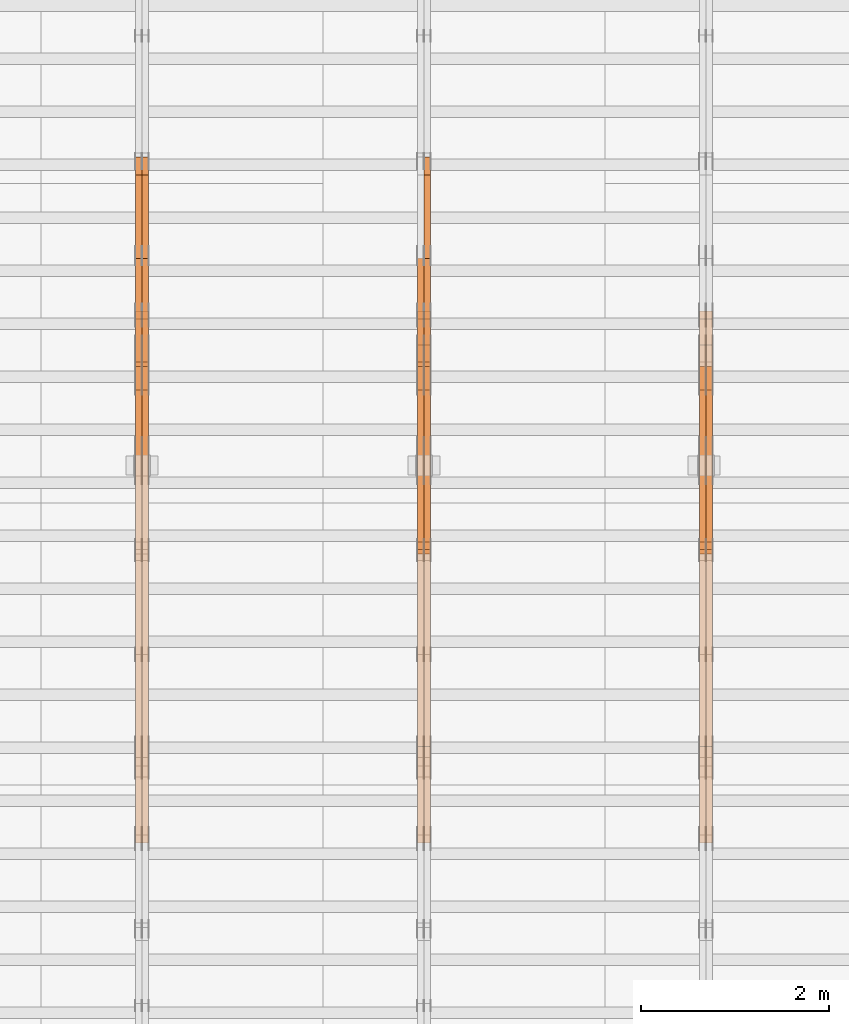
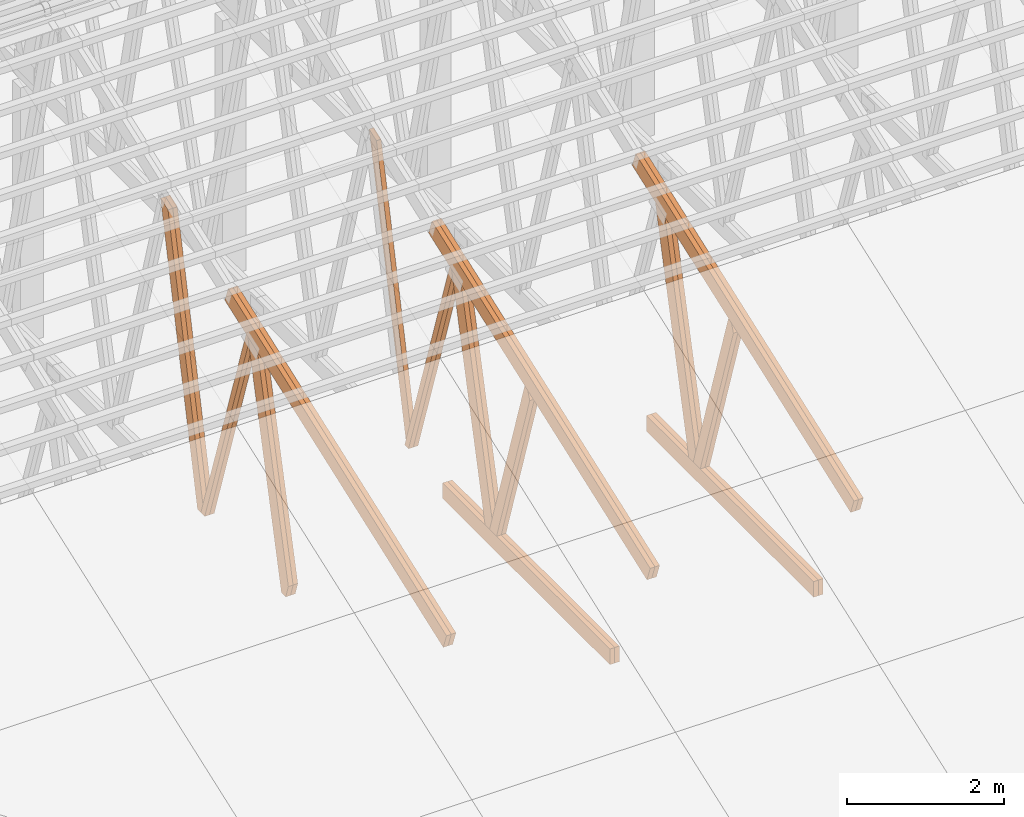
# One storey, part 28 of 189: 27 proxies.
"""IFC2X3 building model written with IfcOpenShell, lengths in millimetres."""

import ifcopenshell
import ifcopenshell.guid

model = None  # the IFC model being written
_history = None  # IfcOwnerHistory: only IFC2X3 demands one
_inside = {}  # id of a spatial element -> (the spatial element, [elements in it])
_under = {}  # id of a project, library or spatial element -> (it, [spatial elements below it])
_declared = {}  # id of a project -> (the project, [libraries it declares])
_typed = {}  # id of a type object -> (the type object, [elements of that type])
_made_of = {}  # id of a material, layer set ... -> (it, [elements and type objects made of it])


def new_model(schema):
    """Start an empty IFC model of exactly this schema.

    Asked for "IFC4X3", IfcOpenShell would pick the latest addendum, in which some entities
    have other attributes; the version numbers below select the first issue.
    IFC2X3 requires an IfcOwnerHistory on every rooted entity: one is made here for all.
    """
    global model, _history
    if schema == "IFC4X3":
        model = ifcopenshell.file(schema_version=(4, 3, 0, 0))
    else:
        model = ifcopenshell.file(schema=schema)
    _inside.clear()
    _under.clear()
    _declared.clear()
    _typed.clear()
    _made_of.clear()
    _history = None
    if model.schema == "IFC2X3":
        org = make("IfcOrganization", Name="unknown")
        user = make(
            "IfcPersonAndOrganization",
            ThePerson=make("IfcPerson", FamilyName="unknown"),
            TheOrganization=org,
        )
        app = make(
            "IfcApplication",
            ApplicationDeveloper=org,
            Version="unknown",
            ApplicationFullName="unknown",
            ApplicationIdentifier="unknown",
        )
        _history = make(
            "IfcOwnerHistory",
            OwningUser=user,
            OwningApplication=app,
            ChangeAction="ADDED",
            CreationDate=0,
        )
    return model


def make(cls, **values):
    """One entity of the class cls with the attributes given. An attribute that is None is left unset."""
    return model.create_entity(
        cls, **{name: value for name, value in values.items() if value is not None}
    )


def entity(cls, *values):
    """Any entity or typed value of the class cls, its attributes in the order of the schema. None: left unset."""
    e = model.create_entity(cls)
    for i, value in enumerate(values):
        if value is not None:
            e[i] = value
    return e


def rooted(cls, **values):
    """An entity with a GlobalId (a new one), such as an element, a storey or a relation."""
    return make(cls, GlobalId=ifcopenshell.guid.new(), OwnerHistory=_history, **values)


def si_unit(unit_type, name, prefix=None):
    """IfcSIUnit, for example si_unit("LENGTHUNIT", "METRE", prefix="MILLI")."""
    return make("IfcSIUnit", UnitType=unit_type, Prefix=prefix, Name=name)


def converted_unit(unit_type, name, factor, base, dimensions=None, offset=None):
    """IfcConversionBasedUnit, such as the inch: factor (a typed value) times the base unit."""
    return make(
        "IfcConversionBasedUnit"
        if offset is None
        else "IfcConversionBasedUnitWithOffset",
        ConversionOffset=offset,
        Dimensions=None
        if dimensions is None
        else entity("IfcDimensionalExponents", *dimensions),
        UnitType=unit_type,
        Name=name,
        ConversionFactor=make(
            "IfcMeasureWithUnit", ValueComponent=factor, UnitComponent=base
        ),
    )


def derived_unit(unit_type, elements):
    """IfcDerivedUnit: a product of units, each with its exponent."""
    return make(
        "IfcDerivedUnit",
        Elements=[
            make("IfcDerivedUnitElement", Unit=unit, Exponent=power)
            for unit, power in elements
        ],
        UnitType=unit_type,
    )


def assignment(units):
    """IfcUnitAssignment: the units of a project."""
    return None if units is None else make("IfcUnitAssignment", Units=units)


def point(xyz):
    """IfcCartesianPoint."""
    return None if xyz is None else make("IfcCartesianPoint", Coordinates=xyz)


def direction(xyz):
    """IfcDirection."""
    return None if xyz is None else make("IfcDirection", DirectionRatios=xyz)


def frame(location, z_axis=None, x_axis=None):
    """IfcAxis2Placement3D, a coordinate frame: its origin and axes. An axis left out is left unset."""
    return make(
        "IfcAxis2Placement3D",
        Location=point(location),
        Axis=direction(z_axis),
        RefDirection=direction(x_axis),
    )


def frame_2d(location, x_axis=None):
    """IfcAxis2Placement2D, a coordinate frame in the plane: its origin and x axis."""
    return make(
        "IfcAxis2Placement2D", Location=point(location), RefDirection=direction(x_axis)
    )


def origin():
    """The frame at (0, 0, 0) with its axes left unset."""
    return frame((0.0, 0.0, 0.0))


def origin_2d_with_axis():
    """The frame at (0, 0) in the plane with the x axis (1, 0) written out."""
    return frame_2d((0.0, 0.0), x_axis=(1.0, 0.0))


def place(relative_to, where):
    """IfcLocalPlacement: puts the frame where relative to a parent placement (None: the world)."""
    return make(
        "IfcLocalPlacement", PlacementRelTo=relative_to, RelativePlacement=where
    )


def context(
    kind, dimensions, precision=None, world=None, true_north=None, identifier=None
):
    """IfcGeometricRepresentationContext, for example the 3D "Model" context."""
    return make(
        "IfcGeometricRepresentationContext",
        ContextIdentifier=identifier,
        ContextType=kind,
        CoordinateSpaceDimension=dimensions,
        Precision=precision,
        WorldCoordinateSystem=world,
        TrueNorth=true_north,
    )


def subcontext(parent, identifier, kind, view, scale=None):
    """IfcGeometricRepresentationSubContext, for example "Body" below "Model"."""
    return make(
        "IfcGeometricRepresentationSubContext",
        ContextIdentifier=identifier,
        ContextType=kind,
        ParentContext=parent,
        TargetScale=scale,
        TargetView=view,
    )


def project(units=None, contexts=None):
    """IfcProject with its units and contexts."""
    return rooted(
        "IfcProject",
        Name="project",
        RepresentationContexts=contexts,
        UnitsInContext=assignment(units),
    )


def spatial(cls, under=None, at=None, **own):
    """A site, building, storey or space (cls), placed at a placement, below another one or the project."""
    s = rooted(cls, ObjectPlacement=at, **own)
    if under is not None:
        _under.setdefault(under.id(), (under, []))[1].append(s)
    return s


def polyline(points):
    """IfcPolyline through the points."""
    return make("IfcPolyline", Points=[point(p) for p in points])


def profile(cls, at=None, kind="AREA", **sizes):
    """A parametric profile (cls). Its sizes go by their IFC names, for example OverallWidth=200.0."""
    return make(cls, ProfileType=kind, Position=at, **sizes)


def rectangle(**sizes):
    """IfcRectangleProfileDef."""
    return profile("IfcRectangleProfileDef", **sizes)


def outline(outer, holes=None, kind="AREA"):
    """IfcArbitraryClosedProfileDef: a profile drawn as a closed curve; with holes, ...WithVoids."""
    if holes is None:
        return make("IfcArbitraryClosedProfileDef", ProfileType=kind, OuterCurve=outer)
    return make(
        "IfcArbitraryProfileDefWithVoids",
        ProfileType=kind,
        OuterCurve=outer,
        InnerCurves=holes,
    )


def extrude(swept, where, along, depth):
    """IfcExtrudedAreaSolid: the profile swept, set in the frame where, extruded along a direction by depth."""
    return make(
        "IfcExtrudedAreaSolid",
        SweptArea=swept,
        Position=where,
        ExtrudedDirection=direction(along),
        Depth=depth,
    )


def shape(context_of_items, identifier, shape_type, items):
    """IfcShapeRepresentation: the items that make up one representation, for example the "Body"."""
    return make(
        "IfcShapeRepresentation",
        ContextOfItems=context_of_items,
        RepresentationIdentifier=identifier,
        RepresentationType=shape_type,
        Items=items,
    )


def source(mapping_origin, context_of_items, identifier, shape_type, items):
    """IfcRepresentationMap: a shape defined once, which mapped items show again and again."""
    return make(
        "IfcRepresentationMap",
        MappingOrigin=mapping_origin,
        MappedRepresentation=shape(context_of_items, identifier, shape_type, items),
    )


def transform(
    local_origin,
    x_axis=None,
    y_axis=None,
    z_axis=None,
    scale=None,
    scale2=None,
    scale3=None,
    uniform=True,
):
    """IfcCartesianTransformationOperator3D, or its non-uniform kind. x_axis, y_axis, z_axis: its Axis1, 2, 3."""
    if uniform:
        return make(
            "IfcCartesianTransformationOperator3D",
            Axis1=direction(x_axis),
            Axis2=direction(y_axis),
            LocalOrigin=point(local_origin),
            Scale=scale,
            Axis3=direction(z_axis),
        )
    return make(
        "IfcCartesianTransformationOperator3DnonUniform",
        Axis1=direction(x_axis),
        Axis2=direction(y_axis),
        LocalOrigin=point(local_origin),
        Scale=scale,
        Axis3=direction(z_axis),
        Scale2=scale2,
        Scale3=scale3,
    )


def mapped(mapping_source, mapping_target):
    """IfcMappedItem: shows the shape of a source again, moved by a transform."""
    return make(
        "IfcMappedItem", MappingSource=mapping_source, MappingTarget=mapping_target
    )


def material(Name=None, Category=None):
    """IfcMaterial."""
    return make("IfcMaterial", Name=Name, Category=Category)


def made_of(thing, what):
    """Note that an element or type object is made of a material, layer set ...; save() writes the relation."""
    if what is not None:
        _made_of.setdefault(what.id(), (what, []))[1].append(thing)
    return thing


def type_object(cls, material=None, **own):
    """A type object (cls), such as IfcWallType, which elements share."""
    return made_of(rooted(cls, **own), material)


def type_shapes(of_type, sources):
    """Give a type object the sources (RepresentationMaps) that its elements show as mapped items."""
    of_type.RepresentationMaps = sources


def element(
    cls,
    number,
    at=None,
    inside=None,
    cuts=None,
    type_object=None,
    material=None,
    context=None,
    identifier="Body",
    shape_type=None,
    held_by="IfcProductDefinitionShape",
    body=None,
    shapes=None,
    **own,
):
    """One element of the class cls, such as IfcWall. Its Tag is "e" and its number.

    at: its placement. inside: the storey or other place that contains it. cuts: it is an
    opening in that element (IfcRelVoidsElement). A single representation is given by context,
    identifier, shape_type and body (its items); several are given by shapes. held_by: the class
    of the entity that holds the representations. save() writes the other relations.
    """
    e = rooted(cls, Tag="e%d" % number, ObjectPlacement=at, **own)
    if body is not None:
        shapes = [shape(context, identifier, shape_type, body)]
    if shapes is not None:
        e.Representation = make(held_by, Representations=shapes)
    if inside is not None:
        _inside.setdefault(inside.id(), (inside, []))[1].append(e)
    if cuts is not None:
        rooted(
            "IfcRelVoidsElement", RelatingBuildingElement=cuts, RelatedOpeningElement=e
        )
    if type_object is not None:
        _typed.setdefault(type_object.id(), (type_object, []))[1].append(e)
    return made_of(e, material)


def aggregate(whole, parts):
    """IfcRelAggregates: a whole, such as a stair, and the parts it consists of."""
    return rooted("IfcRelAggregates", RelatingObject=whole, RelatedObjects=parts)


def save(model, path):
    """Write the relations noted so far, then the file.

    IfcRelAggregates (storeys below a building ...), IfcRelContainedInSpatialStructure (elements
    in a storey), IfcRelDefinesByType, IfcRelAssociatesMaterial and IfcRelDeclares: one each for
    every whole, place, type object, material and project.
    """
    for whole, parts in _under.values():
        aggregate(whole, parts)
    for where, things in _inside.values():
        rooted(
            "IfcRelContainedInSpatialStructure",
            RelatedElements=things,
            RelatingStructure=where,
        )
    for kind, things in _typed.values():
        rooted("IfcRelDefinesByType", RelatedObjects=things, RelatingType=kind)
    for what, things in _made_of.values():
        rooted("IfcRelAssociatesMaterial", RelatedObjects=things, RelatingMaterial=what)
    for by, libraries in _declared.values():
        rooted("IfcRelDeclares", RelatingContext=by, RelatedDefinitions=libraries)
    model.write(path)


model = new_model("IFC2X3")

# Units and contexts
model_context = context("Model", 3, precision=0.01, world=origin(), true_north=direction((6.12303176911189e-17, 1.0)))
body_context = subcontext(model_context, "Body", "Model", "MODEL_VIEW")
ifc_project = project(units=[si_unit("LENGTHUNIT", "METRE", prefix="MILLI"), si_unit("AREAUNIT", "SQUARE_METRE"), si_unit("VOLUMEUNIT", "CUBIC_METRE"), converted_unit("PLANEANGLEUNIT", "DEGREE", entity("IfcRatioMeasure", 0.0174532925199433), si_unit("PLANEANGLEUNIT", "RADIAN"), dimensions=[0, 0, 0, 0, 0, 0, 0]), si_unit("MASSUNIT", "GRAM", prefix="KILO"), derived_unit("MASSDENSITYUNIT", [(si_unit("MASSUNIT", "GRAM", prefix="KILO"), 1), (si_unit("LENGTHUNIT", "METRE"), -3)]), si_unit("TIMEUNIT", "SECOND"), si_unit("FREQUENCYUNIT", "HERTZ"), si_unit("THERMODYNAMICTEMPERATUREUNIT", "DEGREE_CELSIUS"), derived_unit("THERMALTRANSMITTANCEUNIT", [(si_unit("MASSUNIT", "GRAM", prefix="KILO"), 1), (si_unit("THERMODYNAMICTEMPERATUREUNIT", "KELVIN"), -1), (si_unit("TIMEUNIT", "SECOND"), -3)]), derived_unit("VOLUMETRICFLOWRATEUNIT", [(si_unit("LENGTHUNIT", "METRE"), 3), (si_unit("TIMEUNIT", "SECOND"), -1)]), si_unit("ELECTRICCURRENTUNIT", "AMPERE"), si_unit("ELECTRICVOLTAGEUNIT", "VOLT"), si_unit("POWERUNIT", "WATT"), si_unit("FORCEUNIT", "NEWTON"), si_unit("ILLUMINANCEUNIT", "LUX"), si_unit("LUMINOUSFLUXUNIT", "LUMEN"), si_unit("LUMINOUSINTENSITYUNIT", "CANDELA"), derived_unit("USERDEFINED", [(si_unit("MASSUNIT", "GRAM", prefix="KILO"), -1), (si_unit("LENGTHUNIT", "METRE"), -2), (si_unit("TIMEUNIT", "SECOND"), 3), (si_unit("LUMINOUSFLUXUNIT", "LUMEN"), 1)]), derived_unit("LINEARVELOCITYUNIT", [(si_unit("LENGTHUNIT", "METRE"), 1), (si_unit("TIMEUNIT", "SECOND"), -1)]), si_unit("PRESSUREUNIT", "PASCAL"), derived_unit("USERDEFINED", [(si_unit("LENGTHUNIT", "METRE"), -2), (si_unit("MASSUNIT", "GRAM", prefix="KILO"), 1), (si_unit("TIMEUNIT", "SECOND"), -2)])], contexts=[model_context])

# Site, building, storey
site_placement = place(None, origin())
site = spatial("IfcSite", under=ifc_project, at=site_placement, CompositionType="ELEMENT")
building_placement = place(site_placement, origin())
building = spatial("IfcBuilding", under=site, at=building_placement, CompositionType="ELEMENT")
storey_placement = place(building_placement, origin())
storey = spatial("IfcBuildingStorey", under=building, at=storey_placement, Name="Default", CompositionType="ELEMENT", Elevation=0.0)

# Proxies
ifc_material_1 = material(Name="IfcSurfaceStyle #162318")
building_element_proxy_type_1 = type_object("IfcBuildingElementProxyType", Name="T1-W1 162316", PredefinedType="NOTDEFINED", material=ifc_material_1)
shared_shape_1 = source(origin(), body_context, "Body", "SweptSolid", [
    extrude(outline(polyline([(-2144.69382208629, -109.99948311278), (1421.70798092021, -109.99948311278), (1448.88116133745, -0.000392715405943322), (1271.09900468242, 109.999679470483), (-1996.99432485378, 109.999679470483), (-2144.69382208629, -109.99948311278)])), frame((1448.88130194731, 110.000176487146, 0.0), z_axis=(0.0, 0.0, 1.0), x_axis=(-1.0, 0.0, 0.0)), (0.0, 0.0, 1.0), 69.9999999999998),
])
type_shapes(building_element_proxy_type_1, [shared_shape_1])
proxy_1_placement = place(building_placement, frame((30300.0, 8727.74270166583, 271.380182391418), z_axis=(-1.0, 0.0, 0.0), x_axis=(0.0, 0.239819839925978, 0.970817410421691)))
element("IfcBuildingElementProxy", 1, at=proxy_1_placement, inside=storey, type_object=building_element_proxy_type_1, material=ifc_material_1, Name="T1-W1", context=body_context, shape_type="MappedRepresentation", body=[
    mapped(shared_shape_1, transform((0.0, 0.0, 0.0), scale=1.0)),
])
ifc_material_2 = material(Name="IfcSurfaceStyle #162252")
building_element_proxy_type_2 = type_object("IfcBuildingElementProxyType", Name="T1-W1 162250", PredefinedType="NOTDEFINED", material=ifc_material_2)
shared_shape_2 = source(origin(), body_context, "Body", "SweptSolid", [
    extrude(outline(polyline([(-2144.69382208629, -109.99948311278), (1421.70798092021, -109.99948311278), (1448.88116133745, -0.000392715405943322), (1271.09900468242, 109.999679470483), (-1996.99432485378, 109.999679470483), (-2144.69382208629, -109.99948311278)])), frame((1448.88130194731, 110.000176487146, 0.0), z_axis=(0.0, 0.0, 1.0), x_axis=(-1.0, 0.0, 0.0)), (0.0, 0.0, 1.0), 69.9999999999998),
])
type_shapes(building_element_proxy_type_2, [shared_shape_2])
proxy_2_placement = place(building_placement, frame((30230.0, 8727.74270166583, 271.380182391418), z_axis=(-1.0, 0.0, 0.0), x_axis=(0.0, 0.239819839925978, 0.970817410421691)))
element("IfcBuildingElementProxy", 2, at=proxy_2_placement, inside=storey, type_object=building_element_proxy_type_2, material=ifc_material_2, Name="T1-W1", context=body_context, shape_type="MappedRepresentation", body=[
    mapped(shared_shape_2, transform((0.0, 0.0, 0.0), scale=1.0)),
])
ifc_material_3 = material(Name="IfcSurfaceStyle #162054")
building_element_proxy_type_3 = type_object("IfcBuildingElementProxyType", Name="T1-W4 162052", PredefinedType="NOTDEFINED", material=ifc_material_3)
shared_shape_3 = source(origin(), body_context, "Body", "SweptSolid", [
    extrude(outline(polyline([(-1688.09292256655, -85.0003489723785), (1071.44998120742, -85.0003489723785), (1178.19407811536, -0.00016040063201781), (1181.35435681367, 85.0004291726946), (-1742.9054935699, 85.0004291726946), (-1688.09292256655, -85.0003489723785)])), frame((1181.35446122976, 85.0007670757732, 0.0), z_axis=(0.0, 0.0, 1.0), x_axis=(-1.0, 0.0, 0.0)), (0.0, 0.0, 1.0), 69.9999999999998),
])
type_shapes(building_element_proxy_type_3, [shared_shape_3])
proxy_3_placement = place(building_placement, frame((30300.0, 7937.17021143291, 3028.170124945), z_axis=(-1.0, 0.0, 0.0), x_axis=(0.0, 0.306868406216492, -0.951751953644514)))
element("IfcBuildingElementProxy", 3, at=proxy_3_placement, inside=storey, type_object=building_element_proxy_type_3, material=ifc_material_3, Name="T1-W4", context=body_context, shape_type="MappedRepresentation", body=[
    mapped(shared_shape_3, transform((0.0, 0.0, 0.0), scale=1.0)),
])
ifc_material_4 = material(Name="IfcSurfaceStyle #161988")
building_element_proxy_type_4 = type_object("IfcBuildingElementProxyType", Name="T1-W4 161986", PredefinedType="NOTDEFINED", material=ifc_material_4)
shared_shape_4 = source(origin(), body_context, "Body", "SweptSolid", [
    extrude(outline(polyline([(-1688.09292256655, -85.0003489723785), (1071.44998120742, -85.0003489723785), (1178.19407811536, -0.00016040063201781), (1181.35435681367, 85.0004291726946), (-1742.9054935699, 85.0004291726946), (-1688.09292256655, -85.0003489723785)])), frame((1181.35446122976, 85.0007670757732, 0.0), z_axis=(0.0, 0.0, 1.0), x_axis=(-1.0, 0.0, 0.0)), (0.0, 0.0, 1.0), 69.9999999999998),
])
type_shapes(building_element_proxy_type_4, [shared_shape_4])
proxy_4_placement = place(building_placement, frame((30230.0, 7937.17021143291, 3028.170124945), z_axis=(-1.0, 0.0, 0.0), x_axis=(0.0, 0.306868406216492, -0.951751953644514)))
element("IfcBuildingElementProxy", 4, at=proxy_4_placement, inside=storey, type_object=building_element_proxy_type_4, material=ifc_material_4, Name="T1-W4", context=body_context, shape_type="MappedRepresentation", body=[
    mapped(shared_shape_4, transform((0.0, 0.0, 0.0), scale=1.0)),
])
ifc_material_5 = material(Name="IfcSurfaceStyle #158976")
building_element_proxy_type_5 = type_object("IfcBuildingElementProxyType", Name="T1-B6 158974", PredefinedType="NOTDEFINED", material=ifc_material_5)
shared_shape_5 = source(origin(), body_context, "Body", "SweptSolid", [
    extrude(rectangle(XDim=4266.763671875, YDim=245.000000000001, at=origin_2d_with_axis()), frame((2133.3818359375, 122.500000000001, 0.0), z_axis=(0.0, 0.0, 1.0), x_axis=(-1.0, 0.0, 0.0)), (0.0, 0.0, 1.0), 69.9999999999997),
])
type_shapes(building_element_proxy_type_5, [shared_shape_5])
proxy_5_placement = place(building_placement, frame((30300.0, 5762.466796875, 245.0), z_axis=(-1.0, 0.0, 0.0), x_axis=(0.0, 1.0, 0.0)))
element("IfcBuildingElementProxy", 5, at=proxy_5_placement, inside=storey, type_object=building_element_proxy_type_5, material=ifc_material_5, Name="T1-B6", context=body_context, shape_type="MappedRepresentation", body=[
    mapped(shared_shape_5, transform((0.0, 0.0, 0.0), scale=1.0)),
])
ifc_material_6 = material(Name="IfcSurfaceStyle #158919")
building_element_proxy_type_6 = type_object("IfcBuildingElementProxyType", Name="T1-B6 158917", PredefinedType="NOTDEFINED", material=ifc_material_6)
shared_shape_6 = source(origin(), body_context, "Body", "SweptSolid", [
    extrude(rectangle(XDim=4266.763671875, YDim=245.000000000001, at=origin_2d_with_axis()), frame((2133.3818359375, 122.500000000001, 0.0), z_axis=(0.0, 0.0, 1.0), x_axis=(-1.0, 0.0, 0.0)), (0.0, 0.0, 1.0), 69.9999999999997),
])
type_shapes(building_element_proxy_type_6, [shared_shape_6])
proxy_6_placement = place(building_placement, frame((30230.0, 5762.466796875, 245.0), z_axis=(-1.0, 0.0, 0.0), x_axis=(0.0, 1.0, 0.0)))
element("IfcBuildingElementProxy", 6, at=proxy_6_placement, inside=storey, type_object=building_element_proxy_type_6, material=ifc_material_6, Name="T1-B6", context=body_context, shape_type="MappedRepresentation", body=[
    mapped(shared_shape_6, transform((0.0, 0.0, 0.0), scale=1.0)),
])
ifc_material_7 = material(Name="IfcSurfaceStyle #158616")
building_element_proxy_type_7 = type_object("IfcBuildingElementProxyType", Name="T1-T1 158614", PredefinedType="NOTDEFINED", material=ifc_material_7)
shared_shape_7 = source(origin(), body_context, "Body", "SweptSolid", [
    extrude(outline(polyline([(-2964.99981923522, -122.500027388895), (2964.99982426074, -122.500027388895), (2964.99984011048, 122.500027388895), (-2964.99984513599, 122.500027388895), (-2964.99981923522, -122.500027388895)])), frame((2965.00021857317, 122.500056320695, 0.0), z_axis=(0.0, 0.0, 1.0), x_axis=(-1.0, 0.0, 0.0)), (0.0, 0.0, 1.0), 69.9999999999996),
])
type_shapes(building_element_proxy_type_7, [shared_shape_7])
proxy_7_placement = place(building_placement, frame((30300.0, 10391.0374749089, 3921.30478975487), z_axis=(-1.0, 0.0, 0.0), x_axis=(0.0, -0.939692620785908, -0.342020143325669)))
element("IfcBuildingElementProxy", 7, at=proxy_7_placement, inside=storey, type_object=building_element_proxy_type_7, material=ifc_material_7, Name="T1-T1", context=body_context, shape_type="MappedRepresentation", body=[
    mapped(shared_shape_7, transform((0.0, 0.0, 0.0), scale=1.0)),
])
ifc_material_8 = material(Name="IfcSurfaceStyle #158559")
building_element_proxy_type_8 = type_object("IfcBuildingElementProxyType", Name="T1-T1 158557", PredefinedType="NOTDEFINED", material=ifc_material_8)
shared_shape_8 = source(origin(), body_context, "Body", "SweptSolid", [
    extrude(outline(polyline([(-2964.99981923522, -122.500027388895), (2964.99982426074, -122.500027388895), (2964.99984011048, 122.500027388895), (-2964.99984513599, 122.500027388895), (-2964.99981923522, -122.500027388895)])), frame((2965.00021857317, 122.500056320695, 0.0), z_axis=(0.0, 0.0, 1.0), x_axis=(-1.0, 0.0, 0.0)), (0.0, 0.0, 1.0), 69.9999999999996),
])
type_shapes(building_element_proxy_type_8, [shared_shape_8])
proxy_8_placement = place(building_placement, frame((30230.0, 10391.0374749089, 3921.30478975487), z_axis=(-1.0, 0.0, 0.0), x_axis=(0.0, -0.939692620785908, -0.342020143325669)))
element("IfcBuildingElementProxy", 8, at=proxy_8_placement, inside=storey, type_object=building_element_proxy_type_8, material=ifc_material_8, Name="T1-T1", context=body_context, shape_type="MappedRepresentation", body=[
    mapped(shared_shape_8, transform((0.0, 0.0, 0.0), scale=1.0)),
])
ifc_material_9 = material(Name="IfcSurfaceStyle #147056")
building_element_proxy_type_9 = type_object("IfcBuildingElementProxyType", Name="T1-W3 147054", PredefinedType="NOTDEFINED", material=ifc_material_9)
shared_shape_9 = source(origin(), body_context, "Body", "SweptSolid", [
    extrude(outline(polyline([(-2625.55080717397, -84.9998286237256), (1749.48871563991, -84.9998286237256), (1768.20584427244, 0.000602085469291858), (1625.445846867, 85.0000405971208), (-2517.58959960538, 84.9990145648612), (-2625.55080717397, -84.9998286237256)])), frame((1768.20584427244, 85.0000405971208, 0.0), z_axis=(0.0, 0.0, 1.0), x_axis=(-1.0, 0.0, 0.0)), (0.0, 0.0, 1.0), 69.9999999999997),
])
type_shapes(building_element_proxy_type_9, [shared_shape_9])
proxy_9_placement = place(building_placement, frame((27300.0, 10918.6728403286, 263.278932236374), z_axis=(-1.0, 0.0, 0.0), x_axis=(0.0, 0.215047682154604, 0.976603550269982)))
element("IfcBuildingElementProxy", 9, at=proxy_9_placement, inside=storey, type_object=building_element_proxy_type_9, material=ifc_material_9, Name="T1-W3", context=body_context, shape_type="MappedRepresentation", body=[
    mapped(shared_shape_9, transform((0.0, 0.0, 0.0), scale=1.0)),
])
ifc_material_10 = material(Name="IfcSurfaceStyle #146792")
building_element_proxy_type_10 = type_object("IfcBuildingElementProxyType", Name="T1-W7 146790", PredefinedType="NOTDEFINED", material=ifc_material_10)
shared_shape_10 = source(origin(), body_context, "Body", "SweptSolid", [
    extrude(outline(polyline([(-2158.15323194511, -47.5001976605119), (1398.58481981178, -47.5001976605119), (1473.93376219819, -0.000131511554346808), (1475.30069254941, 47.5002634162891), (-2189.66604261427, 47.5002634162891), (-2158.15323194511, -47.5001976605119)])), frame((1475.30069254941, 47.5002634162891, 0.0), z_axis=(0.0, 0.0, 1.0), x_axis=(-1.0, 0.0, 0.0)), (0.0, 0.0, 1.0), 69.9999999999998),
])
type_shapes(building_element_proxy_type_10, [shared_shape_10])
proxy_10_placement = place(building_placement, frame((27300.0, 9847.787109375, 3723.57788085937), z_axis=(-1.0, 0.0, 0.0), x_axis=(0.0, 0.314845237923105, -0.949143021971475)))
element("IfcBuildingElementProxy", 10, at=proxy_10_placement, inside=storey, type_object=building_element_proxy_type_10, material=ifc_material_10, Name="T1-W7", context=body_context, shape_type="MappedRepresentation", body=[
    mapped(shared_shape_10, transform((0.0, 0.0, 0.0), scale=1.0)),
])
ifc_material_11 = material(Name="IfcSurfaceStyle #146726")
building_element_proxy_type_11 = type_object("IfcBuildingElementProxyType", Name="T1-W7 146724", PredefinedType="NOTDEFINED", material=ifc_material_11)
shared_shape_11 = source(origin(), body_context, "Body", "SweptSolid", [
    extrude(outline(polyline([(-2158.15323194511, -47.5001976605119), (1398.58481981178, -47.5001976605119), (1473.93376219819, -0.000131511554346808), (1475.30069254941, 47.5002634162891), (-2189.66604261427, 47.5002634162891), (-2158.15323194511, -47.5001976605119)])), frame((1475.30069254941, 47.5002634162891, 0.0), z_axis=(0.0, 0.0, 1.0), x_axis=(-1.0, 0.0, 0.0)), (0.0, 0.0, 1.0), 69.9999999999998),
])
type_shapes(building_element_proxy_type_11, [shared_shape_11])
proxy_11_placement = place(building_placement, frame((27230.0, 9847.787109375, 3723.57788085937), z_axis=(-1.0, 0.0, 0.0), x_axis=(0.0, 0.314845237923105, -0.949143021971475)))
element("IfcBuildingElementProxy", 11, at=proxy_11_placement, inside=storey, type_object=building_element_proxy_type_11, material=ifc_material_11, Name="T1-W7", context=body_context, shape_type="MappedRepresentation", body=[
    mapped(shared_shape_11, transform((0.0, 0.0, 0.0), scale=1.0)),
])
ifc_material_12 = material(Name="IfcSurfaceStyle #146528")
building_element_proxy_type_12 = type_object("IfcBuildingElementProxyType", Name="T1-W1 146526", PredefinedType="NOTDEFINED", material=ifc_material_12)
shared_shape_12 = source(origin(), body_context, "Body", "SweptSolid", [
    extrude(outline(polyline([(-2144.69382208629, -109.99948311278), (1421.70798092021, -109.99948311278), (1448.88116133745, -0.000392715405943322), (1271.09900468242, 109.999679470483), (-1996.99432485378, 109.999679470483), (-2144.69382208629, -109.99948311278)])), frame((1448.88130194731, 110.000176487146, 0.0), z_axis=(0.0, 0.0, 1.0), x_axis=(-1.0, 0.0, 0.0)), (0.0, 0.0, 1.0), 69.9999999999998),
])
type_shapes(building_element_proxy_type_12, [shared_shape_12])
proxy_12_placement = place(building_placement, frame((27300.0, 8727.74270166583, 271.380182391418), z_axis=(-1.0, 0.0, 0.0), x_axis=(0.0, 0.239819839925978, 0.970817410421691)))
element("IfcBuildingElementProxy", 12, at=proxy_12_placement, inside=storey, type_object=building_element_proxy_type_12, material=ifc_material_12, Name="T1-W1", context=body_context, shape_type="MappedRepresentation", body=[
    mapped(shared_shape_12, transform((0.0, 0.0, 0.0), scale=1.0)),
])
ifc_material_13 = material(Name="IfcSurfaceStyle #146462")
building_element_proxy_type_13 = type_object("IfcBuildingElementProxyType", Name="T1-W1 146460", PredefinedType="NOTDEFINED", material=ifc_material_13)
shared_shape_13 = source(origin(), body_context, "Body", "SweptSolid", [
    extrude(outline(polyline([(-2144.69382208629, -109.99948311278), (1421.70798092021, -109.99948311278), (1448.88116133745, -0.000392715405943322), (1271.09900468242, 109.999679470483), (-1996.99432485378, 109.999679470483), (-2144.69382208629, -109.99948311278)])), frame((1448.88130194731, 110.000176487146, 0.0), z_axis=(0.0, 0.0, 1.0), x_axis=(-1.0, 0.0, 0.0)), (0.0, 0.0, 1.0), 69.9999999999998),
])
type_shapes(building_element_proxy_type_13, [shared_shape_13])
proxy_13_placement = place(building_placement, frame((27230.0, 8727.74270166583, 271.380182391418), z_axis=(-1.0, 0.0, 0.0), x_axis=(0.0, 0.239819839925978, 0.970817410421691)))
element("IfcBuildingElementProxy", 13, at=proxy_13_placement, inside=storey, type_object=building_element_proxy_type_13, material=ifc_material_13, Name="T1-W1", context=body_context, shape_type="MappedRepresentation", body=[
    mapped(shared_shape_13, transform((0.0, 0.0, 0.0), scale=1.0)),
])
ifc_material_14 = material(Name="IfcSurfaceStyle #146264")
building_element_proxy_type_14 = type_object("IfcBuildingElementProxyType", Name="T1-W4 146262", PredefinedType="NOTDEFINED", material=ifc_material_14)
shared_shape_14 = source(origin(), body_context, "Body", "SweptSolid", [
    extrude(outline(polyline([(-1688.09292256655, -85.0003489723785), (1071.44998120742, -85.0003489723785), (1178.19407811536, -0.00016040063201781), (1181.35435681367, 85.0004291726946), (-1742.9054935699, 85.0004291726946), (-1688.09292256655, -85.0003489723785)])), frame((1181.35446122976, 85.0007670757732, 0.0), z_axis=(0.0, 0.0, 1.0), x_axis=(-1.0, 0.0, 0.0)), (0.0, 0.0, 1.0), 69.9999999999998),
])
type_shapes(building_element_proxy_type_14, [shared_shape_14])
proxy_14_placement = place(building_placement, frame((27300.0, 7937.17021143291, 3028.170124945), z_axis=(-1.0, 0.0, 0.0), x_axis=(0.0, 0.306868406216492, -0.951751953644514)))
element("IfcBuildingElementProxy", 14, at=proxy_14_placement, inside=storey, type_object=building_element_proxy_type_14, material=ifc_material_14, Name="T1-W4", context=body_context, shape_type="MappedRepresentation", body=[
    mapped(shared_shape_14, transform((0.0, 0.0, 0.0), scale=1.0)),
])
ifc_material_15 = material(Name="IfcSurfaceStyle #146198")
building_element_proxy_type_15 = type_object("IfcBuildingElementProxyType", Name="T1-W4 146196", PredefinedType="NOTDEFINED", material=ifc_material_15)
shared_shape_15 = source(origin(), body_context, "Body", "SweptSolid", [
    extrude(outline(polyline([(-1688.09292256655, -85.0003489723785), (1071.44998120742, -85.0003489723785), (1178.19407811536, -0.00016040063201781), (1181.35435681367, 85.0004291726946), (-1742.9054935699, 85.0004291726946), (-1688.09292256655, -85.0003489723785)])), frame((1181.35446122976, 85.0007670757732, 0.0), z_axis=(0.0, 0.0, 1.0), x_axis=(-1.0, 0.0, 0.0)), (0.0, 0.0, 1.0), 69.9999999999998),
])
type_shapes(building_element_proxy_type_15, [shared_shape_15])
proxy_15_placement = place(building_placement, frame((27230.0, 7937.17021143291, 3028.170124945), z_axis=(-1.0, 0.0, 0.0), x_axis=(0.0, 0.306868406216492, -0.951751953644514)))
element("IfcBuildingElementProxy", 15, at=proxy_15_placement, inside=storey, type_object=building_element_proxy_type_15, material=ifc_material_15, Name="T1-W4", context=body_context, shape_type="MappedRepresentation", body=[
    mapped(shared_shape_15, transform((0.0, 0.0, 0.0), scale=1.0)),
])
ifc_material_16 = material(Name="IfcSurfaceStyle #143186")
building_element_proxy_type_16 = type_object("IfcBuildingElementProxyType", Name="T1-B6 143184", PredefinedType="NOTDEFINED", material=ifc_material_16)
shared_shape_16 = source(origin(), body_context, "Body", "SweptSolid", [
    extrude(rectangle(XDim=4266.763671875, YDim=245.000000000001, at=origin_2d_with_axis()), frame((2133.3818359375, 122.500000000001, 0.0), z_axis=(0.0, 0.0, 1.0), x_axis=(-1.0, 0.0, 0.0)), (0.0, 0.0, 1.0), 69.9999999999997),
])
type_shapes(building_element_proxy_type_16, [shared_shape_16])
proxy_16_placement = place(building_placement, frame((27300.0, 5762.466796875, 245.0), z_axis=(-1.0, 0.0, 0.0), x_axis=(0.0, 1.0, 0.0)))
element("IfcBuildingElementProxy", 16, at=proxy_16_placement, inside=storey, type_object=building_element_proxy_type_16, material=ifc_material_16, Name="T1-B6", context=body_context, shape_type="MappedRepresentation", body=[
    mapped(shared_shape_16, transform((0.0, 0.0, 0.0), scale=1.0)),
])
ifc_material_17 = material(Name="IfcSurfaceStyle #143129")
building_element_proxy_type_17 = type_object("IfcBuildingElementProxyType", Name="T1-B6 143127", PredefinedType="NOTDEFINED", material=ifc_material_17)
shared_shape_17 = source(origin(), body_context, "Body", "SweptSolid", [
    extrude(rectangle(XDim=4266.763671875, YDim=245.000000000001, at=origin_2d_with_axis()), frame((2133.3818359375, 122.500000000001, 0.0), z_axis=(0.0, 0.0, 1.0), x_axis=(-1.0, 0.0, 0.0)), (0.0, 0.0, 1.0), 69.9999999999997),
])
type_shapes(building_element_proxy_type_17, [shared_shape_17])
proxy_17_placement = place(building_placement, frame((27230.0, 5762.466796875, 245.0), z_axis=(-1.0, 0.0, 0.0), x_axis=(0.0, 1.0, 0.0)))
element("IfcBuildingElementProxy", 17, at=proxy_17_placement, inside=storey, type_object=building_element_proxy_type_17, material=ifc_material_17, Name="T1-B6", context=body_context, shape_type="MappedRepresentation", body=[
    mapped(shared_shape_17, transform((0.0, 0.0, 0.0), scale=1.0)),
])
ifc_material_18 = material(Name="IfcSurfaceStyle #142826")
building_element_proxy_type_18 = type_object("IfcBuildingElementProxyType", Name="T1-T1 142824", PredefinedType="NOTDEFINED", material=ifc_material_18)
shared_shape_18 = source(origin(), body_context, "Body", "SweptSolid", [
    extrude(outline(polyline([(-2964.99981923522, -122.500027388895), (2964.99982426074, -122.500027388895), (2964.99984011048, 122.500027388895), (-2964.99984513599, 122.500027388895), (-2964.99981923522, -122.500027388895)])), frame((2965.00021857317, 122.500056320695, 0.0), z_axis=(0.0, 0.0, 1.0), x_axis=(-1.0, 0.0, 0.0)), (0.0, 0.0, 1.0), 69.9999999999996),
])
type_shapes(building_element_proxy_type_18, [shared_shape_18])
proxy_18_placement = place(building_placement, frame((27300.0, 10391.0374749089, 3921.30478975487), z_axis=(-1.0, 0.0, 0.0), x_axis=(0.0, -0.939692620785908, -0.342020143325669)))
element("IfcBuildingElementProxy", 18, at=proxy_18_placement, inside=storey, type_object=building_element_proxy_type_18, material=ifc_material_18, Name="T1-T1", context=body_context, shape_type="MappedRepresentation", body=[
    mapped(shared_shape_18, transform((0.0, 0.0, 0.0), scale=1.0)),
])
ifc_material_19 = material(Name="IfcSurfaceStyle #142769")
building_element_proxy_type_19 = type_object("IfcBuildingElementProxyType", Name="T1-T1 142767", PredefinedType="NOTDEFINED", material=ifc_material_19)
shared_shape_19 = source(origin(), body_context, "Body", "SweptSolid", [
    extrude(outline(polyline([(-2964.99981923522, -122.500027388895), (2964.99982426074, -122.500027388895), (2964.99984011048, 122.500027388895), (-2964.99984513599, 122.500027388895), (-2964.99981923522, -122.500027388895)])), frame((2965.00021857317, 122.500056320695, 0.0), z_axis=(0.0, 0.0, 1.0), x_axis=(-1.0, 0.0, 0.0)), (0.0, 0.0, 1.0), 69.9999999999996),
])
type_shapes(building_element_proxy_type_19, [shared_shape_19])
proxy_19_placement = place(building_placement, frame((27230.0, 10391.0374749089, 3921.30478975487), z_axis=(-1.0, 0.0, 0.0), x_axis=(0.0, -0.939692620785908, -0.342020143325669)))
element("IfcBuildingElementProxy", 19, at=proxy_19_placement, inside=storey, type_object=building_element_proxy_type_19, material=ifc_material_19, Name="T1-T1", context=body_context, shape_type="MappedRepresentation", body=[
    mapped(shared_shape_19, transform((0.0, 0.0, 0.0), scale=1.0)),
])
ifc_material_20 = material(Name="IfcSurfaceStyle #131266")
building_element_proxy_type_20 = type_object("IfcBuildingElementProxyType", Name="T1-W3 131264", PredefinedType="NOTDEFINED", material=ifc_material_20)
shared_shape_20 = source(origin(), body_context, "Body", "SweptSolid", [
    extrude(outline(polyline([(-2625.55080717397, -84.9998286237256), (1749.48871563991, -84.9998286237256), (1768.20584427244, 0.000602085469291858), (1625.445846867, 85.0000405971208), (-2517.58959960538, 84.9990145648612), (-2625.55080717397, -84.9998286237256)])), frame((1768.20584427244, 85.0000405971208, 0.0), z_axis=(0.0, 0.0, 1.0), x_axis=(-1.0, 0.0, 0.0)), (0.0, 0.0, 1.0), 69.9999999999997),
])
type_shapes(building_element_proxy_type_20, [shared_shape_20])
proxy_20_placement = place(building_placement, frame((24300.0, 10918.6728403286, 263.278932236374), z_axis=(-1.0, 0.0, 0.0), x_axis=(0.0, 0.215047682154604, 0.976603550269982)))
element("IfcBuildingElementProxy", 20, at=proxy_20_placement, inside=storey, type_object=building_element_proxy_type_20, material=ifc_material_20, Name="T1-W3", context=body_context, shape_type="MappedRepresentation", body=[
    mapped(shared_shape_20, transform((0.0, 0.0, 0.0), scale=1.0)),
])
ifc_material_21 = material(Name="IfcSurfaceStyle #131200")
building_element_proxy_type_21 = type_object("IfcBuildingElementProxyType", Name="T1-W3 131198", PredefinedType="NOTDEFINED", material=ifc_material_21)
shared_shape_21 = source(origin(), body_context, "Body", "SweptSolid", [
    extrude(outline(polyline([(-2625.55080717397, -84.9998286237256), (1749.48871563991, -84.9998286237256), (1768.20584427244, 0.000602085469291858), (1625.445846867, 85.0000405971208), (-2517.58959960538, 84.9990145648612), (-2625.55080717397, -84.9998286237256)])), frame((1768.20584427244, 85.0000405971208, 0.0), z_axis=(0.0, 0.0, 1.0), x_axis=(-1.0, 0.0, 0.0)), (0.0, 0.0, 1.0), 69.9999999999997),
])
type_shapes(building_element_proxy_type_21, [shared_shape_21])
proxy_21_placement = place(building_placement, frame((24230.0, 10918.6728403286, 263.278932236374), z_axis=(-1.0, 0.0, 0.0), x_axis=(0.0, 0.215047682154604, 0.976603550269982)))
element("IfcBuildingElementProxy", 21, at=proxy_21_placement, inside=storey, type_object=building_element_proxy_type_21, material=ifc_material_21, Name="T1-W3", context=body_context, shape_type="MappedRepresentation", body=[
    mapped(shared_shape_21, transform((0.0, 0.0, 0.0), scale=1.0)),
])
ifc_material_22 = material(Name="IfcSurfaceStyle #131002")
building_element_proxy_type_22 = type_object("IfcBuildingElementProxyType", Name="T1-W7 131000", PredefinedType="NOTDEFINED", material=ifc_material_22)
shared_shape_22 = source(origin(), body_context, "Body", "SweptSolid", [
    extrude(outline(polyline([(-2158.15323194511, -47.5001976605119), (1398.58481981178, -47.5001976605119), (1473.93376219819, -0.000131511554346808), (1475.30069254941, 47.5002634162891), (-2189.66604261427, 47.5002634162891), (-2158.15323194511, -47.5001976605119)])), frame((1475.30069254941, 47.5002634162891, 0.0), z_axis=(0.0, 0.0, 1.0), x_axis=(-1.0, 0.0, 0.0)), (0.0, 0.0, 1.0), 69.9999999999998),
])
type_shapes(building_element_proxy_type_22, [shared_shape_22])
proxy_22_placement = place(building_placement, frame((24300.0, 9847.787109375, 3723.57788085937), z_axis=(-1.0, 0.0, 0.0), x_axis=(0.0, 0.314845237923105, -0.949143021971475)))
element("IfcBuildingElementProxy", 22, at=proxy_22_placement, inside=storey, type_object=building_element_proxy_type_22, material=ifc_material_22, Name="T1-W7", context=body_context, shape_type="MappedRepresentation", body=[
    mapped(shared_shape_22, transform((0.0, 0.0, 0.0), scale=1.0)),
])
ifc_material_23 = material(Name="IfcSurfaceStyle #130936")
building_element_proxy_type_23 = type_object("IfcBuildingElementProxyType", Name="T1-W7 130934", PredefinedType="NOTDEFINED", material=ifc_material_23)
shared_shape_23 = source(origin(), body_context, "Body", "SweptSolid", [
    extrude(outline(polyline([(-2158.15323194511, -47.5001976605119), (1398.58481981178, -47.5001976605119), (1473.93376219819, -0.000131511554346808), (1475.30069254941, 47.5002634162891), (-2189.66604261427, 47.5002634162891), (-2158.15323194511, -47.5001976605119)])), frame((1475.30069254941, 47.5002634162891, 0.0), z_axis=(0.0, 0.0, 1.0), x_axis=(-1.0, 0.0, 0.0)), (0.0, 0.0, 1.0), 69.9999999999998),
])
type_shapes(building_element_proxy_type_23, [shared_shape_23])
proxy_23_placement = place(building_placement, frame((24230.0, 9847.787109375, 3723.57788085937), z_axis=(-1.0, 0.0, 0.0), x_axis=(0.0, 0.314845237923105, -0.949143021971475)))
element("IfcBuildingElementProxy", 23, at=proxy_23_placement, inside=storey, type_object=building_element_proxy_type_23, material=ifc_material_23, Name="T1-W7", context=body_context, shape_type="MappedRepresentation", body=[
    mapped(shared_shape_23, transform((0.0, 0.0, 0.0), scale=1.0)),
])
ifc_material_24 = material(Name="IfcSurfaceStyle #130738")
building_element_proxy_type_24 = type_object("IfcBuildingElementProxyType", Name="T1-W1 130736", PredefinedType="NOTDEFINED", material=ifc_material_24)
shared_shape_24 = source(origin(), body_context, "Body", "SweptSolid", [
    extrude(outline(polyline([(-2144.69382208629, -109.99948311278), (1421.70798092021, -109.99948311278), (1448.88116133745, -0.000392715405943322), (1271.09900468242, 109.999679470483), (-1996.99432485378, 109.999679470483), (-2144.69382208629, -109.99948311278)])), frame((1448.88130194731, 110.000176487146, 0.0), z_axis=(0.0, 0.0, 1.0), x_axis=(-1.0, 0.0, 0.0)), (0.0, 0.0, 1.0), 69.9999999999998),
])
type_shapes(building_element_proxy_type_24, [shared_shape_24])
proxy_24_placement = place(building_placement, frame((24300.0, 8727.74270166583, 271.380182391418), z_axis=(-1.0, 0.0, 0.0), x_axis=(0.0, 0.239819839925978, 0.970817410421691)))
element("IfcBuildingElementProxy", 24, at=proxy_24_placement, inside=storey, type_object=building_element_proxy_type_24, material=ifc_material_24, Name="T1-W1", context=body_context, shape_type="MappedRepresentation", body=[
    mapped(shared_shape_24, transform((0.0, 0.0, 0.0), scale=1.0)),
])
ifc_material_25 = material(Name="IfcSurfaceStyle #130672")
building_element_proxy_type_25 = type_object("IfcBuildingElementProxyType", Name="T1-W1 130670", PredefinedType="NOTDEFINED", material=ifc_material_25)
shared_shape_25 = source(origin(), body_context, "Body", "SweptSolid", [
    extrude(outline(polyline([(-2144.69382208629, -109.99948311278), (1421.70798092021, -109.99948311278), (1448.88116133745, -0.000392715405943322), (1271.09900468242, 109.999679470483), (-1996.99432485378, 109.999679470483), (-2144.69382208629, -109.99948311278)])), frame((1448.88130194731, 110.000176487146, 0.0), z_axis=(0.0, 0.0, 1.0), x_axis=(-1.0, 0.0, 0.0)), (0.0, 0.0, 1.0), 69.9999999999998),
])
type_shapes(building_element_proxy_type_25, [shared_shape_25])
proxy_25_placement = place(building_placement, frame((24230.0, 8727.74270166583, 271.380182391418), z_axis=(-1.0, 0.0, 0.0), x_axis=(0.0, 0.239819839925978, 0.970817410421691)))
element("IfcBuildingElementProxy", 25, at=proxy_25_placement, inside=storey, type_object=building_element_proxy_type_25, material=ifc_material_25, Name="T1-W1", context=body_context, shape_type="MappedRepresentation", body=[
    mapped(shared_shape_25, transform((0.0, 0.0, 0.0), scale=1.0)),
])
ifc_material_26 = material(Name="IfcSurfaceStyle #127036")
building_element_proxy_type_26 = type_object("IfcBuildingElementProxyType", Name="T1-T1 127034", PredefinedType="NOTDEFINED", material=ifc_material_26)
shared_shape_26 = source(origin(), body_context, "Body", "SweptSolid", [
    extrude(outline(polyline([(-2964.99981923522, -122.500027388895), (2964.99982426074, -122.500027388895), (2964.99984011048, 122.500027388895), (-2964.99984513599, 122.500027388895), (-2964.99981923522, -122.500027388895)])), frame((2965.00021857317, 122.500056320695, 0.0), z_axis=(0.0, 0.0, 1.0), x_axis=(-1.0, 0.0, 0.0)), (0.0, 0.0, 1.0), 69.9999999999996),
])
type_shapes(building_element_proxy_type_26, [shared_shape_26])
proxy_26_placement = place(building_placement, frame((24300.0, 10391.0374749089, 3921.30478975487), z_axis=(-1.0, 0.0, 0.0), x_axis=(0.0, -0.939692620785908, -0.342020143325669)))
element("IfcBuildingElementProxy", 26, at=proxy_26_placement, inside=storey, type_object=building_element_proxy_type_26, material=ifc_material_26, Name="T1-T1", context=body_context, shape_type="MappedRepresentation", body=[
    mapped(shared_shape_26, transform((0.0, 0.0, 0.0), scale=1.0)),
])
ifc_material_27 = material(Name="IfcSurfaceStyle #126979")
building_element_proxy_type_27 = type_object("IfcBuildingElementProxyType", Name="T1-T1 126977", PredefinedType="NOTDEFINED", material=ifc_material_27)
shared_shape_27 = source(origin(), body_context, "Body", "SweptSolid", [
    extrude(outline(polyline([(-2964.99981923522, -122.500027388895), (2964.99982426074, -122.500027388895), (2964.99984011048, 122.500027388895), (-2964.99984513599, 122.500027388895), (-2964.99981923522, -122.500027388895)])), frame((2965.00021857317, 122.500056320695, 0.0), z_axis=(0.0, 0.0, 1.0), x_axis=(-1.0, 0.0, 0.0)), (0.0, 0.0, 1.0), 69.9999999999996),
])
type_shapes(building_element_proxy_type_27, [shared_shape_27])
proxy_27_placement = place(building_placement, frame((24230.0, 10391.0374749089, 3921.30478975487), z_axis=(-1.0, 0.0, 0.0), x_axis=(0.0, -0.939692620785908, -0.342020143325669)))
element("IfcBuildingElementProxy", 27, at=proxy_27_placement, inside=storey, type_object=building_element_proxy_type_27, material=ifc_material_27, Name="T1-T1", context=body_context, shape_type="MappedRepresentation", body=[
    mapped(shared_shape_27, transform((0.0, 0.0, 0.0), scale=1.0)),
])

save(model, "model.ifc")
